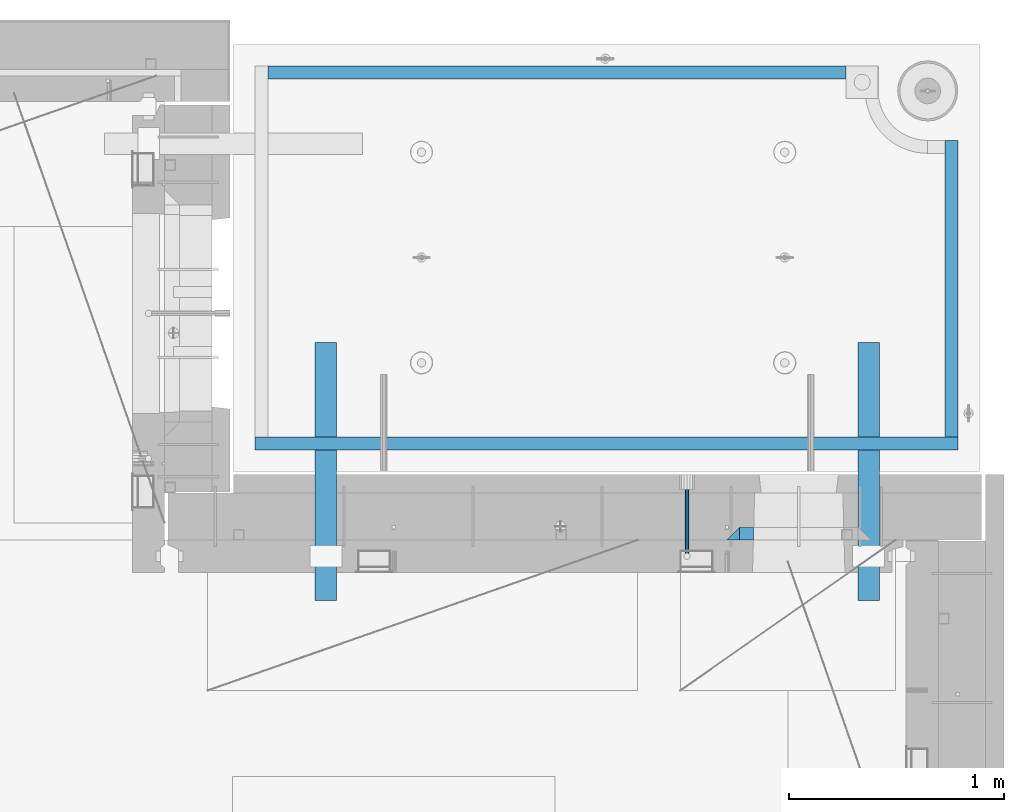
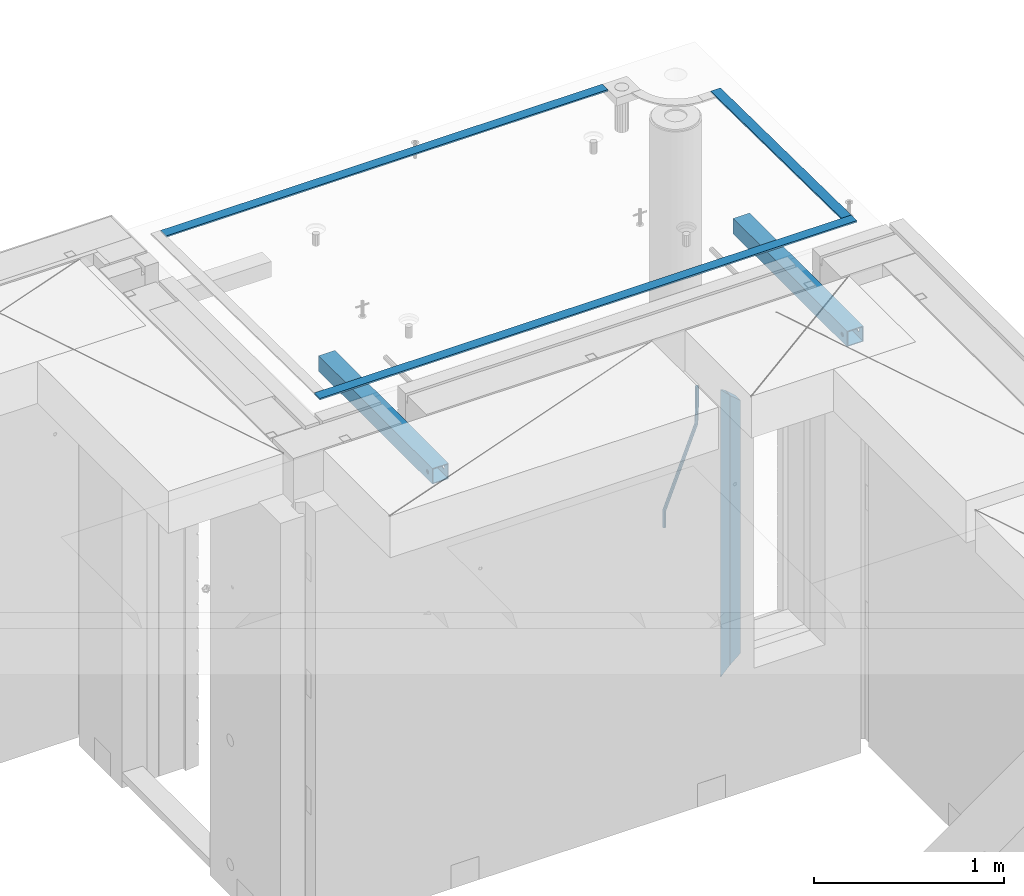
# One storey, part 134 of 352: 8 beams, 4 elements without a shape of their own.
"""IFC2X3 building model written with IfcOpenShell, lengths in millimetres."""

from ifc_helpers import new_model, si_unit, frame, origin_with_axes, place, context, subcontext, project, spatial, faceted_brep, material, type_object, element, aggregate, save


model = new_model("IFC2X3")

# Units and contexts
model_context = context("Model", 3, precision=1e-05, world=origin_with_axes())
body_context = subcontext(model_context, "Body", "Model", "MODEL_VIEW")
ifc_project = project(units=[si_unit("LENGTHUNIT", "METRE", prefix="MILLI"), si_unit("AREAUNIT", "SQUARE_METRE"), si_unit("VOLUMEUNIT", "CUBIC_METRE"), si_unit("MASSUNIT", "GRAM", prefix="KILO"), si_unit("TIMEUNIT", "SECOND"), si_unit("PLANEANGLEUNIT", "RADIAN"), si_unit("SOLIDANGLEUNIT", "STERADIAN"), si_unit("THERMODYNAMICTEMPERATUREUNIT", "DEGREE_CELSIUS"), si_unit("LUMINOUSINTENSITYUNIT", "LUMEN")], contexts=[model_context])

# Site, building, storey
site_placement = place(None, origin_with_axes())
site = spatial("IfcSite", under=ifc_project, at=site_placement, CompositionType="ELEMENT")
building_placement = place(site_placement, origin_with_axes())
building = spatial("IfcBuilding", under=site, at=building_placement, CompositionType="ELEMENT")
storey_placement = place(building_placement, origin_with_axes())
storey = spatial("IfcBuildingStorey", under=building, at=storey_placement, Name="6", CompositionType="ELEMENT", Elevation=0.0)

# Assembly, beam
assembly_1_placement = place(storey_placement, origin_with_axes())
assembly_1 = element("IfcElementAssembly", 1, at=assembly_1_placement, inside=storey, AssemblyPlace="NOTDEFINED", PredefinedType="REINFORCEMENT_UNIT")
ifc_material_1 = material()
beam_type_1 = type_object("IfcBeamType", Name="D20", PredefinedType="NOTDEFINED")
beam_1_placement = place(assembly_1_placement, frame((33889.995187329, 20504.9951872346, 99407.5), z_axis=(0.000415599999849905, 0.999999913638203, 4.76000000899737e-07), x_axis=(0.0, 0.0, -1.0)))
beam_1 = element("IfcBeam", 2, at=beam_1_placement, type_object=beam_type_1, material=ifc_material_1, Name="JM20", ObjectType="D20", context=body_context, shape_type="Brep", body=[
    faceted_brep([(-0.00060564729210455, -9.99999998165731, 0.0), (-0.000428079845733009, -7.07106779890455, -7.07106781186667), (119.575515501536, -7.07830994756296, -7.07106481604933), (119.575337932896, -10.0072421307195, -3.43332612828817e-06), (0.0, 0.0, -10.0), (119.575943836026, -0.00724214867295814, -9.99999700418266), (0.00042843479604926, 7.07106779888636, -7.07106781186303), (119.57637202373, 7.06382565022977, -7.07106481604933), (0.00060564729210455, 9.99999998166459, 3.63797880709171e-12), (119.576549238118, 9.99275783300072, 2.99581552098971e-06), (0.000428079845733009, 7.07106779890819, 7.07106781186667), (119.576371669405, 7.06382565024978, 7.07107080768037), (0.0, 0.0, 10.0), (119.57594333493, -0.00724214864203532, 10.0000029958155), (-0.000428434810601175, -7.07106779888272, 7.07106781186667), (119.575515147211, -7.07830994754295, 7.07107080768037), (123.00654325854, -7.07836650239551, -6.96786008391246), (122.581588830741, -10.007295666459, 0.0904344953341933), (123.182419066041, -0.00729994480025198, -9.89151006310021), (123.006190977103, 7.06376911688858, -6.96788735351402), (122.581091016109, 9.99270432680532, 0.0903895128230943), (122.156136974867, 7.06377516229986, 7.14867767459873), (121.980261167351, -0.00729139528993983, 10.0723276537792), (122.156489256289, -7.07836045697513, 7.14870494419847), (237.077376207715, -7.07551629289992, -0.0988779924864502), (236.652422053201, -10.0044409119728, 6.95941204931296), (237.253252288647, -0.0044516184279928, -3.02253250974718), (237.077024472936, 7.06661932641327, -0.0989143382521434), (236.651924624995, 9.99555908263574, 6.95936064834314), (236.226970470365, 7.06663446442326, 14.0176506898479), (236.051094389448, -0.0044302100486675, 16.9413052071086), (236.227322205144, -7.07550115488812, 14.0176870356117), (256.715938387759, -7.07353516174771, 4.66794781703175), (253.858321224223, -10.0027051854922, 11.1357628166734), (257.898622435067, -0.00236892073007766, 1.98867362452802), (256.713573090979, 7.0686002544353, 4.66742272414376), (253.85497618909, 9.99729452004976, 11.1350202234971), (250.997359025234, 7.06812449537756, 17.6028352234607), (249.814674977912, -0.00304174564189452, 20.2821094159572), (250.999724322028, -7.07401092080545, 17.6033603163596), (1009.84102825288, -6.93521658215468, 337.477148757798), (1006.98341108896, -9.86438660663771, 343.944963757851), (1011.02371230032, 0.135949658781101, 334.7978745651), (1009.83866295629, 7.20691883402651, 337.476623664521), (1006.98006605446, 10.1356130998429, 343.944221163818), (1004.12244889054, 7.2064430753635, 350.412036163872), (1002.9397648431, 0.135276834424076, 353.091310356571), (1004.12481418712, -6.93569234081951, 350.412561257146), (1010.86335274603, -6.9350288225487, 337.928918327354), (1009.37086865908, -9.86394812736762, 344.999991477531), (1011.48104818776, 0.136033652863262, 334.999973251377), (1010.86211737194, 7.20710680115553, 337.928892551665), (1009.36912157628, 10.1360518725905, 344.9999550252), (1007.87663748935, 7.2071325677698, 352.071028175378), (1007.2589420476, 0.13607009235966, 354.999973251352), (1007.87787286344, -6.93500305593261, 352.071053951067), (1011.98104820926, -6.93502881915083, 337.92891832735), (1011.98104821818, -9.86394811943501, 344.999991477524), (1011.98104818776, 0.136033654382118, 334.999973251375), (1011.98104816627, 7.20710680455704, 337.928892551661), (1011.98104815738, 10.1360518805304, 344.999955025194), (1011.98104816629, 7.20713258024625, 352.071028175369), (1011.98104818778, 0.136070106711486, 354.999973251342), (1011.98104820927, -6.9350030434598, 352.071053951058), (1117.50000002154, -6.93502849844299, 337.928918327156), (1117.50000003044, -9.86394779872717, 344.999991477331), (1117.50000000004, 0.136033975091777, 334.999973251181), (1117.49999997855, 7.20710712526488, 337.928892551467), (1117.49999996964, 10.1360522012383, 344.999955025), (1117.49999997857, 7.20713290095409, 352.071028175174), (1117.50000000006, 0.136070427419327, 354.999973251148), (1117.50000002155, -6.93500272275196, 352.071053950864)], [[[0, 1, 2, 3]], [[1, 4, 5, 2]], [[4, 6, 7, 5]], [[6, 8, 9, 7]], [[8, 10, 11, 9]], [[10, 12, 13, 11]], [[12, 14, 15, 13]], [[14, 0, 3, 15]], [[14, 12, 10, 8, 6, 4, 1, 0]], [[3, 2, 16, 17]], [[2, 5, 18, 16]], [[5, 7, 19, 18]], [[7, 9, 20, 19]], [[9, 11, 21, 20]], [[11, 13, 22, 21]], [[13, 15, 23, 22]], [[15, 3, 17, 23]], [[17, 16, 24, 25]], [[16, 18, 26, 24]], [[18, 19, 27, 26]], [[19, 20, 28, 27]], [[20, 21, 29, 28]], [[21, 22, 30, 29]], [[22, 23, 31, 30]], [[23, 17, 25, 31]], [[25, 24, 32, 33]], [[24, 26, 34, 32]], [[26, 27, 35, 34]], [[27, 28, 36, 35]], [[28, 29, 37, 36]], [[29, 30, 38, 37]], [[30, 31, 39, 38]], [[31, 25, 33, 39]], [[33, 32, 40, 41]], [[32, 34, 42, 40]], [[34, 35, 43, 42]], [[35, 36, 44, 43]], [[36, 37, 45, 44]], [[37, 38, 46, 45]], [[38, 39, 47, 46]], [[39, 33, 41, 47]], [[41, 40, 48, 49]], [[40, 42, 50, 48]], [[42, 43, 51, 50]], [[43, 44, 52, 51]], [[44, 45, 53, 52]], [[45, 46, 54, 53]], [[46, 47, 55, 54]], [[47, 41, 49, 55]], [[49, 48, 56, 57]], [[48, 50, 58, 56]], [[50, 51, 59, 58]], [[51, 52, 60, 59]], [[52, 53, 61, 60]], [[53, 54, 62, 61]], [[54, 55, 63, 62]], [[55, 49, 57, 63]], [[57, 56, 64, 65]], [[56, 58, 66, 64]], [[58, 59, 67, 66]], [[59, 60, 68, 67]], [[60, 61, 69, 68]], [[61, 62, 70, 69]], [[62, 63, 71, 70]], [[63, 57, 65, 71]], [[66, 67, 68, 69, 70, 71, 65, 64]]]),
])

# Assemblies, beams
assembly_2_placement = place(storey_placement, origin_with_axes())
assembly_2 = element("IfcElementAssembly", 3, at=assembly_2_placement, inside=storey, AssemblyPlace="NOTDEFINED", PredefinedType="REINFORCEMENT_UNIT")
assembly_3_placement = place(assembly_2_placement, origin_with_axes())
assembly_3 = element("IfcElementAssembly", 4, at=assembly_3_placement, AssemblyPlace="NOTDEFINED", PredefinedType="NOTDEFINED")
ifc_material_2 = material(Name="Undefined/350")
beam_type_2 = type_object("IfcBeamType", Name="100X100X5", PredefinedType="NOTDEFINED")
beam_2_placement = place(assembly_3_placement, frame((34735.0001432011, 21500.0034426031, 99555.0), z_axis=(0.0, 0.0, 1.0), x_axis=(-2.2242999997242e-05, -0.999999999752625, 0.0)))
beam_2 = element("IfcBeam", 5, at=beam_2_placement, type_object=beam_type_2, material=ifc_material_2, ObjectType="100X100X5", context=body_context, shape_type="Brep", body=[
    faceted_brep([(1143.75108023171, 44.9999999999982, -10.8253175473074), (1143.75107855316, 50.0255964196231, -10.8253175473074), (1139.17576100585, 50.0255948914664, -6.25), (1139.1757626844, 44.9999999999982, -6.25), (1150.00108023171, 44.9999999999982, -12.5), (1150.00107855316, 50.0255985071226, -12.5), (1156.2510802317, 44.9999999999982, -10.8253175473074), (1156.25107855315, 50.0256005946221, -10.8253175473074), (1160.82639777901, 44.9999999999982, -6.25), (1160.82639610046, 50.0256021227788, -6.25), (1162.50108023171, 44.9999999999982, 0.0), (1162.50107855316, 50.0256026821226, 0.0), (1160.82639777901, 44.9999999999982, 6.25), (1160.82639610046, 50.0256021227788, 6.25), (1156.2510802317, 44.9999999999982, 10.8253175473074), (1156.25107855315, 50.0256005946221, 10.8253175473074), (1150.00108023171, 44.9999999999982, 12.5), (1150.00107855316, 50.0255985071226, 12.5), (1143.75108023171, 44.9999999999982, 10.8253175473074), (1143.75107855316, 50.0255964196231, 10.8253175473074), (1139.1757626844, 44.9999999999982, 6.25), (1139.17576100585, 50.0255948914664, 6.25), (1137.5010802317, 44.9999999999982, 0.0), (1137.50107855316, 50.0255943321226, 0.0), (1143.75111195316, -49.9744035792783, -10.8253175473074), (1143.75111029171, -44.9999999999991, -10.8253175473074), (1139.1757927444, -44.9999999999991, -6.25), (1139.17579440585, -49.9744051074349, -6.25), (1150.00111195316, -49.9744014917787, -12.5), (1150.00111029171, -44.9999999999991, -12.5), (1156.25111195316, -49.9743994042774, -10.8253175473074), (1156.25111029171, -44.9999999999991, -10.8253175473074), (1160.82642950046, -49.9743978761207, -6.25), (1160.82642783901, -44.9999999999991, -6.25), (1162.50111195316, -49.9743973167779, 0.0), (1162.50111029171, -44.9999999999991, 0.0), (1160.82642950046, -49.9743978761207, 6.25), (1160.82642783901, -44.9999999999991, 6.25), (1156.25111195316, -49.9743994042774, 10.8253175473074), (1156.25111029171, -44.9999999999991, 10.8253175473074), (1150.00111195316, -49.9744014917787, 12.5), (1150.00111029171, -44.9999999999991, 12.5), (1143.75111195316, -49.9744035792783, 10.8253175473074), (1143.75111029171, -44.9999999999991, 10.8253175473074), (1139.17579440585, -49.9744051074349, 6.25), (1139.1757927444, -44.9999999999991, 6.25), (1137.50111195316, -49.9744056667778, 0.0), (1137.50111029171, -44.9999999999991, 0.0), (1.81898940354586e-12, -50.0000000000009, -50.0), (1.81898940354586e-12, 49.9999999999991, -50.0), (1200.00449189278, 49.9999999999982, -50.0), (1200.00449189278, -50.0000000000009, -50.0), (1.81898940354586e-12, 49.9999999999991, 50.0), (1.81898940354586e-12, -50.0000000000009, 50.0), (1200.00449189278, -50.0000000000009, 50.0), (1200.00449189278, 49.9999999999982, 50.0), (0.0, 44.9999999999991, 45.0), (1.81898940354586e-12, -45.0000000000009, 45.0), (1.81898940354586e-12, -45.0000000000009, -45.0), (0.0, 44.9999999999991, -45.0), (1200.00449189278, 44.9999999999982, -45.0), (1200.00449189278, 44.9999999999982, 45.0), (1200.00449189278, -45.0000000000009, 45.0), (1200.00449189278, -45.0000000000009, -45.0)], [[[0, 1, 2, 3]], [[4, 5, 1, 0]], [[6, 7, 5, 4]], [[8, 9, 7, 6]], [[10, 11, 9, 8]], [[12, 13, 11, 10]], [[14, 15, 13, 12]], [[16, 17, 15, 14]], [[18, 19, 17, 16]], [[20, 21, 19, 18]], [[22, 23, 21, 20]], [[3, 2, 23, 22]], [[24, 25, 26, 27]], [[28, 29, 25, 24]], [[30, 31, 29, 28]], [[32, 33, 31, 30]], [[34, 35, 33, 32]], [[36, 37, 35, 34]], [[38, 39, 37, 36]], [[40, 41, 39, 38]], [[42, 43, 41, 40]], [[44, 45, 43, 42]], [[46, 47, 45, 44]], [[27, 26, 47, 46]], [[48, 49, 50, 51]], [[52, 53, 54, 55]], [[49, 52, 55, 50], [15, 17, 19, 21, 23, 2, 1, 5, 7, 9, 11, 13]], [[48, 53, 52, 49], [56, 57, 58, 59]], [[56, 59, 60, 61], [6, 4, 0, 3, 22, 20, 18, 16, 14, 12, 10, 8]], [[57, 56, 61, 62]], [[58, 57, 62, 63], [39, 41, 43, 45, 47, 26, 25, 29, 31, 33, 35, 37]], [[59, 58, 63, 60]], [[54, 51, 50, 55], [62, 61, 60, 63]], [[53, 48, 51, 54], [30, 28, 24, 27, 46, 44, 42, 40, 38, 36, 34, 32]]]),
])
aggregate(assembly_3, [beam_2])
assembly_4_placement = place(assembly_2_placement, origin_with_axes())
assembly_4 = element("IfcElementAssembly", 6, at=assembly_4_placement, AssemblyPlace="NOTDEFINED", PredefinedType="NOTDEFINED")
beam_3_placement = place(assembly_4_placement, frame((32210.0001432011, 21500.0034426031, 99555.0), z_axis=(0.0, 0.0, 1.0), x_axis=(-2.2242999997242e-05, -0.999999999752625, 0.0)))
beam_3 = element("IfcBeam", 7, at=beam_3_placement, type_object=beam_type_2, material=ifc_material_2, ObjectType="100X100X5", context=body_context, shape_type="Brep", body=[
    faceted_brep([(1143.75108023171, 44.9999999999982, -10.8253175473074), (1143.75107855316, 50.0255964196231, -10.8253175473074), (1139.17576100585, 50.0255948914664, -6.25), (1139.1757626844, 44.9999999999982, -6.25), (1150.00108023171, 44.9999999999982, -12.5), (1150.00107855316, 50.0255985071226, -12.5), (1156.2510802317, 44.9999999999982, -10.8253175473074), (1156.25107855315, 50.0256005946221, -10.8253175473074), (1160.82639777901, 44.9999999999982, -6.25), (1160.82639610046, 50.0256021227788, -6.25), (1162.50108023171, 44.9999999999982, 0.0), (1162.50107855316, 50.0256026821226, 0.0), (1160.82639777901, 44.9999999999982, 6.25), (1160.82639610046, 50.0256021227788, 6.25), (1156.2510802317, 44.9999999999982, 10.8253175473074), (1156.25107855315, 50.0256005946221, 10.8253175473074), (1150.00108023171, 44.9999999999982, 12.5), (1150.00107855316, 50.0255985071226, 12.5), (1143.75108023171, 44.9999999999982, 10.8253175473074), (1143.75107855316, 50.0255964196231, 10.8253175473074), (1139.1757626844, 44.9999999999982, 6.25), (1139.17576100585, 50.0255948914664, 6.25), (1137.5010802317, 44.9999999999982, 0.0), (1137.50107855316, 50.0255943321226, 0.0), (1143.75111195316, -49.9744035792783, -10.8253175473074), (1143.75111029171, -44.9999999999991, -10.8253175473074), (1139.1757927444, -44.9999999999991, -6.25), (1139.17579440585, -49.9744051074349, -6.25), (1150.00111195316, -49.9744014917787, -12.5), (1150.00111029171, -44.9999999999991, -12.5), (1156.25111195316, -49.9743994042774, -10.8253175473074), (1156.25111029171, -44.9999999999991, -10.8253175473074), (1160.82642950046, -49.9743978761207, -6.25), (1160.82642783901, -44.9999999999991, -6.25), (1162.50111195316, -49.9743973167779, 0.0), (1162.50111029171, -44.9999999999991, 0.0), (1160.82642950046, -49.9743978761207, 6.25), (1160.82642783901, -44.9999999999991, 6.25), (1156.25111195316, -49.9743994042774, 10.8253175473074), (1156.25111029171, -44.9999999999991, 10.8253175473074), (1150.00111195316, -49.9744014917787, 12.5), (1150.00111029171, -44.9999999999991, 12.5), (1143.75111195316, -49.9744035792783, 10.8253175473074), (1143.75111029171, -44.9999999999991, 10.8253175473074), (1139.17579440585, -49.9744051074349, 6.25), (1139.1757927444, -44.9999999999991, 6.25), (1137.50111195316, -49.9744056667778, 0.0), (1137.50111029171, -44.9999999999991, 0.0), (1.81898940354586e-12, -50.0000000000009, -50.0), (1.81898940354586e-12, 49.9999999999991, -50.0), (1200.00449189278, 49.9999999999982, -50.0), (1200.00449189278, -50.0000000000009, -50.0), (1.81898940354586e-12, 49.9999999999991, 50.0), (1.81898940354586e-12, -50.0000000000009, 50.0), (1200.00449189278, -50.0000000000009, 50.0), (1200.00449189278, 49.9999999999982, 50.0), (0.0, 44.9999999999991, 45.0), (1.81898940354586e-12, -45.0000000000009, 45.0), (1.81898940354586e-12, -45.0000000000009, -45.0), (0.0, 44.9999999999991, -45.0), (1200.00449189278, 44.9999999999982, -45.0), (1200.00449189278, 44.9999999999982, 45.0), (1200.00449189278, -45.0000000000009, 45.0), (1200.00449189278, -45.0000000000009, -45.0)], [[[0, 1, 2, 3]], [[4, 5, 1, 0]], [[6, 7, 5, 4]], [[8, 9, 7, 6]], [[10, 11, 9, 8]], [[12, 13, 11, 10]], [[14, 15, 13, 12]], [[16, 17, 15, 14]], [[18, 19, 17, 16]], [[20, 21, 19, 18]], [[22, 23, 21, 20]], [[3, 2, 23, 22]], [[24, 25, 26, 27]], [[28, 29, 25, 24]], [[30, 31, 29, 28]], [[32, 33, 31, 30]], [[34, 35, 33, 32]], [[36, 37, 35, 34]], [[38, 39, 37, 36]], [[40, 41, 39, 38]], [[42, 43, 41, 40]], [[44, 45, 43, 42]], [[46, 47, 45, 44]], [[27, 26, 47, 46]], [[48, 49, 50, 51]], [[52, 53, 54, 55]], [[49, 52, 55, 50], [15, 17, 19, 21, 23, 2, 1, 5, 7, 9, 11, 13]], [[48, 53, 52, 49], [56, 57, 58, 59]], [[56, 59, 60, 61], [6, 4, 0, 3, 22, 20, 18, 16, 14, 12, 10, 8]], [[57, 56, 61, 62]], [[58, 57, 62, 63], [39, 41, 43, 45, 47, 26, 25, 29, 31, 33, 35, 37]], [[59, 58, 63, 60]], [[54, 51, 50, 55], [62, 61, 60, 63]], [[53, 48, 51, 54], [30, 28, 24, 27, 46, 44, 42, 40, 38, 36, 34, 32]]]),
])
aggregate(assembly_4, [beam_3])
ifc_material_3 = material(Name="CONCRETE/Concrete_Undefined")
beam_type_3 = type_object("IfcBeamType", PredefinedType="NOTDEFINED")
beam_4_placement = place(assembly_2_placement, frame((31939.9962088653, 22755.0460044164, 99704.8214945676), z_axis=(-6.06120000110142e-05, 1.00000033869885e-09, 0.999999998163093), x_axis=(0.999999998046552, -1.52670000006885e-05, 6.06120000021532e-05)))
beam_4 = element("IfcBeam", 8, at=beam_4_placement, type_object=beam_type_3, material=ifc_material_3, context=body_context, shape_type="Brep", body=[
    faceted_brep([(2.5465851649642e-11, 29.9999999999982, -4.99999999998545), (-2.91038304567337e-11, 29.9999999999982, 5.0), (2689.99575395095, 29.9999999999964, 5.0), (2689.99575395095, 30.0000000000036, -4.99999999998545), (-2.5465851649642e-11, -30.0000000000018, 5.0), (2689.99575395095, -30.0000000000036, 5.00000000001455), (2.72848410531878e-11, -30.0000000000018, -4.99999999998545), (2689.99575395095, -29.9999999999964, -4.99999999998545)], [[[0, 1, 2, 3]], [[1, 4, 5, 2]], [[4, 6, 7, 5]], [[6, 0, 3, 7]], [[5, 7, 3, 2]], [[6, 4, 1, 0]]]),
])
beam_5_placement = place(assembly_2_placement, frame((35120.0586113047, 21059.9283388168, 99725.6638339053), z_axis=(-5.46000002942176e-07, 0.0130421150000144, 0.999914948001093), x_axis=(-4.18520000064741e-05, 0.999914947125351, -0.0130421150016393)))
beam_5 = element("IfcBeam", 9, at=beam_5_placement, type_object=beam_type_3, material=ifc_material_3, context=body_context, shape_type="Brep", body=[
    faceted_brep([(2.5465851649642e-11, 29.9999999999982, -4.99999999998545), (-2.91038304567337e-11, 29.9999999999982, 5.0), (1380.14316164461, 30.0, 5.00000000001455), (1380.1431616447, 29.9999999999927, -5.0), (-2.5465851649642e-11, -30.0000000000018, 5.0), (1380.14316164461, -30.0, 5.00000000001455), (2.72848410531878e-11, -30.0000000000018, -4.99999999998545), (1380.1431616447, -30.0, -5.0)], [[[0, 1, 2, 3]], [[1, 4, 5, 2]], [[4, 6, 7, 5]], [[6, 0, 3, 7]], [[5, 7, 3, 2]], [[6, 4, 1, 0]]]),
])
beam_6_placement = place(assembly_2_placement, frame((31879.9986204165, 21030.068155681, 99725.2788443041), z_axis=(-0.000117617000009658, 3.00000101585662e-09, 0.999999993083121), x_axis=(0.999999992839137, -2.20899999960382e-05, 0.000117616999982089)))
beam_6 = element("IfcBeam", 10, at=beam_6_placement, type_object=beam_type_3, material=ifc_material_3, context=body_context, shape_type="Brep", body=[
    faceted_brep([(2.5465851649642e-11, 29.9999999999982, -4.99999999998545), (-2.91038304567337e-11, 29.9999999999982, 5.0), (3270.06002088557, 30.0, 5.0), (3270.06002088557, 30.0000000000036, -5.0), (-2.5465851649642e-11, -30.0000000000018, 5.0), (3270.06002088557, -30.0, 5.0), (2.72848410531878e-11, -30.0000000000018, -4.99999999998545), (3270.06002088558, -29.9999999999964, -5.0)], [[[0, 1, 2, 3]], [[1, 4, 5, 2]], [[4, 6, 7, 5]], [[6, 0, 3, 7]], [[5, 7, 3, 2]], [[6, 4, 1, 0]]]),
])
aggregate(assembly_2, [assembly_3, assembly_4, beam_4, beam_5, beam_6])

# Beam
ifc_material_4 = material(Name="CONCRETE/C25/30")
beam_type_4 = type_object("IfcBeamType", PredefinedType="NOTDEFINED")
beam_7_placement = place(assembly_1_placement, frame((34105.0055090716, 20609.9951872276, 99275.0), z_axis=(1.0, 0.0, 0.0), x_axis=(0.0, 0.0, -1.0)))
beam_7 = element("IfcBeam", 11, at=beam_7_placement, type_object=beam_type_4, material=ifc_material_4, Name="SK", context=body_context, shape_type="Brep", body=[
    faceted_brep([(60.0000000000073, 30.0, 30.0), (0.0, -30.0, -30.0), (60.0000000000073, -30.0, 30.0), (1795.00000000001, 30.0, 30.0), (1855.0, -30.0, -30.0), (1795.00000000001, -30.0, 30.0)], [[[0, 1, 2]], [[3, 4, 1, 0]], [[4, 5, 2, 1]], [[5, 3, 0, 2]], [[5, 4, 3]]]),
])

beam_type_5 = type_object("IfcBeamType", PredefinedType="NOTDEFINED")
beam_8_placement = place(assembly_1_placement, frame((34170.0055090716, 20609.9951872276, 99215.0), z_axis=(1.0, 0.0, 0.0), x_axis=(0.0, 0.0, -1.0)))
beam_8 = element("IfcBeam", 12, at=beam_8_placement, type_object=beam_type_5, material=ifc_material_4, Name="SK", context=body_context, shape_type="Brep", body=[
    faceted_brep([(0.0, -30.0, -35.0), (54.9034748914273, -30.0, 29.0540540540533), (56.2934362811066, 30.0, 30.6756756756768), (0.0, 30.0, -35.0), (1678.70656371891, 30.0, 30.6756756756768), (1735.0, 30.0, -35.0), (1735.0, -30.0, -35.0), (1680.09652510857, -30.0, 29.0540540540533)], [[[0, 1, 2, 3]], [[3, 2, 4, 5]], [[5, 6, 0, 3]], [[1, 0, 6, 7]], [[2, 1, 7, 4]], [[6, 5, 4, 7]]]),
])

aggregate(assembly_1, [beam_1, beam_8, beam_7])

save(model, "model.ifc")
